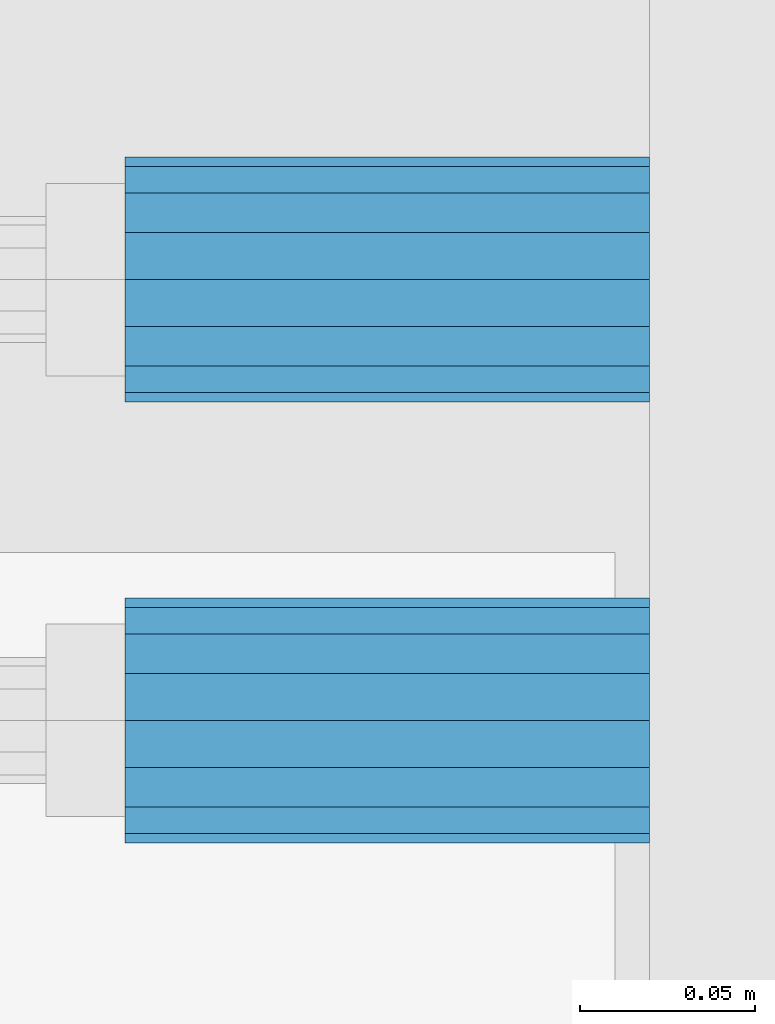
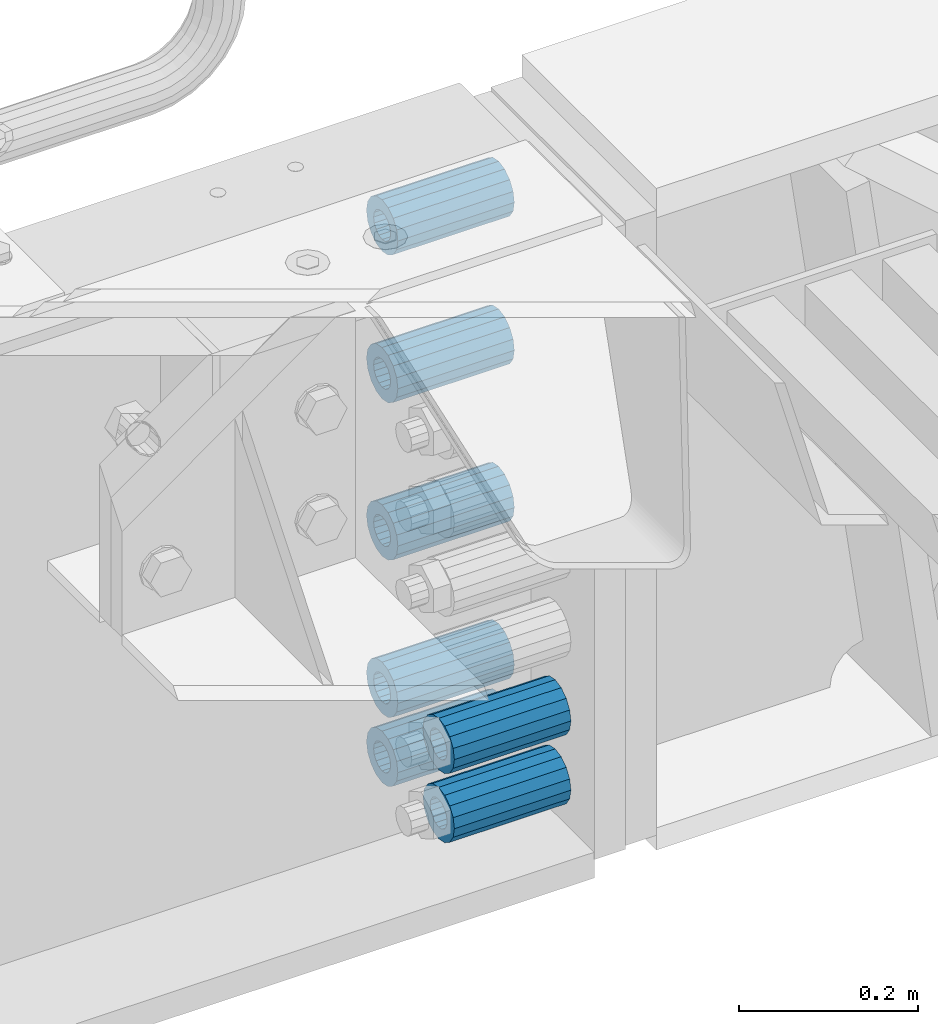
# One storey, part 172 of 242: 7 beams.
"""IFC2X3 building model written with IfcOpenShell, lengths in millimetres."""

from ifc_helpers import new_model, si_unit, frame, origin_with_axes, place, context, subcontext, project, spatial, faceted_brep, material, type_object, element, save


model = new_model("IFC2X3")

# Units and contexts
model_context = context("Model", 3, precision=1e-05, world=origin_with_axes())
body_context = subcontext(model_context, "Body", "Model", "MODEL_VIEW")
ifc_project = project(units=[si_unit("LENGTHUNIT", "METRE", prefix="MILLI"), si_unit("AREAUNIT", "SQUARE_METRE"), si_unit("VOLUMEUNIT", "CUBIC_METRE"), si_unit("MASSUNIT", "GRAM", prefix="KILO"), si_unit("TIMEUNIT", "SECOND"), si_unit("PLANEANGLEUNIT", "RADIAN"), si_unit("SOLIDANGLEUNIT", "STERADIAN"), si_unit("THERMODYNAMICTEMPERATUREUNIT", "DEGREE_CELSIUS"), si_unit("LUMINOUSINTENSITYUNIT", "LUMEN")], contexts=[model_context])

# Site, building, storey
site_placement = place(None, origin_with_axes())
site = spatial("IfcSite", under=ifc_project, at=site_placement, CompositionType="ELEMENT")
building_placement = place(site_placement, origin_with_axes())
building = spatial("IfcBuilding", under=site, at=building_placement, Name="Standard", CompositionType="ELEMENT")
storey_placement = place(building_placement, origin_with_axes())
storey = spatial("IfcBuildingStorey", under=building, at=storey_placement, Name="Undefined", CompositionType="ELEMENT", Elevation=0.0)

# Beams
ifc_material = material()
beam_type = type_object("IfcBeamType", PredefinedType="NOTDEFINED")
beam_1_placement = place(storey_placement, frame((-22210.0, -17937.0, -718.0), z_axis=(0.0, 0.0, 1.0), x_axis=(1.0, 0.0, 0.0)))
element("IfcBeam", 1, at=beam_1_placement, inside=storey, type_object=beam_type, material=ifc_material, context=body_context, shape_type="Brep", body=[
    faceted_brep([(1.33248249767348e-07, -19.0000000004493, -6.26823748461902e-09), (0.0, -17.5537111177146, 7.27098521493673), (150.0, -17.5537111177146, 7.27098521493673), (150.0, -19.0, 0.0), (0.0, -13.4350288425449, 13.4350288425444), (150.0, -13.4350288425449, 13.4350288425444), (0.0, -7.27098521493826, 17.5537111177144), (150.0, -7.27098521493826, 17.5537111177144), (-6.29370333626866e-09, -4.49290382675827e-10, 18.9999999937318), (150.0, 0.0, 19.0), (0.0, 7.27098521493826, 17.5537111177144), (150.0, 7.27098521493826, 17.5537111177144), (0.0, 13.4350288425449, 13.4350288425444), (150.0, 13.4350288425449, 13.4350288425444), (0.0, 17.5537111177146, 7.2709852149367), (150.0, 17.5537111177146, 7.2709852149367), (-1.31243723444641e-07, 18.9999999995507, -6.26823748461902e-09), (150.0, 19.0, 0.0), (0.0, 17.5537111177146, -7.2709852149367), (150.0, 17.5537111177146, -7.2709852149367), (0.0, 13.4350288425449, -13.4350288425444), (150.0, 13.4350288425449, -13.4350288425444), (0.0, 7.27098521493826, -17.5537111177144), (150.0, 7.27098521493826, -17.5537111177144), (8.2982296589762e-09, -4.49290382675827e-10, -19.0000000062719), (150.0, 0.0, -19.0), (0.0, -7.27098521493826, -17.5537111177144), (150.0, -7.27098521493826, -17.5537111177144), (0.0, -13.4350288425449, -13.4350288425444), (150.0, -13.4350288425449, -13.4350288425444), (0.0, -17.5537111177146, -7.2709852149367), (150.0, -17.5537111177146, -7.2709852149367), (-3.63797880709171e-12, -35.0, 0.0), (-3.63797880709171e-12, -32.335783637895, -13.3939201327812), (150.0, -32.3357836378964, -13.3939201327782), (150.0, -35.0, 0.0), (0.0, -24.7487373415292, -24.7487373415315), (150.0, -24.7487373415279, -24.7487373415292), (0.0, -13.3939201327782, -32.3357836378964), (150.0, -13.3939201327776, -32.335783637895), (0.0, 0.0, -35.0000000000036), (150.0, 0.0, -35.0), (0.0, 13.3939201327782, -32.3357836378964), (150.0, 13.3939201327776, -32.335783637895), (0.0, 24.7487373415292, -24.7487373415315), (150.0, 24.7487373415279, -24.7487373415292), (-3.63797880709171e-12, 32.335783637895, -13.3939201327812), (150.0, 32.3357836378964, -13.3939201327781), (-3.63797880709171e-12, 35.0, 0.0), (150.0, 35.0, 0.0), (-7.27595761418343e-12, 32.335783637895, 13.3939201327739), (150.0, 32.3357836378964, 13.3939201327781), (-7.27595761418343e-12, 24.7487373415292, 24.7487373415242), (150.0, 24.7487373415279, 24.7487373415292), (-7.27595761418343e-12, 13.3939201327781, 32.3357836378891), (150.0, 13.3939201327776, 32.335783637895), (-1.09139364212751e-11, 0.0, 34.9999999999964), (150.0, 0.0, 35.0), (-7.27595761418343e-12, -13.3939201327781, 32.3357836378891), (150.0, -13.3939201327776, 32.335783637895), (-7.27595761418343e-12, -24.7487373415292, 24.7487373415242), (150.0, -24.7487373415279, 24.7487373415292), (-7.27595761418343e-12, -32.335783637895, 13.3939201327739), (150.0, -32.3357836378964, 13.3939201327781)], [[[0, 1, 2, 3]], [[1, 4, 5, 2]], [[4, 6, 7, 5]], [[6, 8, 9, 7]], [[8, 10, 11, 9]], [[10, 12, 13, 11]], [[12, 14, 15, 13]], [[14, 16, 17, 15]], [[16, 18, 19, 17]], [[18, 20, 21, 19]], [[20, 22, 23, 21]], [[22, 24, 25, 23]], [[24, 26, 27, 25]], [[26, 28, 29, 27]], [[28, 30, 31, 29]], [[30, 0, 3, 31]], [[32, 33, 34, 35]], [[33, 36, 37, 34]], [[36, 38, 39, 37]], [[38, 40, 41, 39]], [[40, 42, 43, 41]], [[42, 44, 45, 43]], [[44, 46, 47, 45]], [[46, 48, 49, 47]], [[48, 50, 51, 49]], [[50, 52, 53, 51]], [[52, 54, 55, 53]], [[54, 56, 57, 55]], [[56, 58, 59, 57]], [[58, 60, 61, 59]], [[60, 62, 63, 61]], [[62, 32, 35, 63]], [[37, 39, 41, 43, 45, 47, 49, 51, 53, 55, 57, 59, 61, 63, 35, 34], [5, 7, 9, 11, 13, 15, 17, 19, 21, 23, 25, 27, 29, 31, 3, 2]], [[62, 60, 58, 56, 54, 52, 50, 48, 46, 44, 42, 40, 38, 36, 33, 32], [30, 28, 26, 24, 22, 20, 18, 16, 14, 12, 10, 8, 6, 4, 1, 0]]]),
])
beam_2_placement = place(storey_placement, frame((-22210.0, -17937.0, -504.0), z_axis=(0.0, 0.0, 1.0), x_axis=(1.0, 0.0, 0.0)))
element("IfcBeam", 2, at=beam_2_placement, inside=storey, type_object=beam_type, material=ifc_material, context=body_context, shape_type="Brep", body=[
    faceted_brep([(1.33248249767348e-07, -19.0000000004493, -6.26823748461902e-09), (0.0, -17.5537111177146, 7.27098521493673), (150.0, -17.5537111177146, 7.27098521493673), (150.0, -19.0, 0.0), (0.0, -13.4350288425449, 13.4350288425444), (150.0, -13.4350288425449, 13.4350288425444), (0.0, -7.27098521493826, 17.5537111177144), (150.0, -7.27098521493826, 17.5537111177144), (-6.29370333626866e-09, -4.49290382675827e-10, 18.9999999937318), (150.0, 0.0, 19.0), (0.0, 7.27098521493826, 17.5537111177144), (150.0, 7.27098521493826, 17.5537111177144), (0.0, 13.4350288425449, 13.4350288425444), (150.0, 13.4350288425449, 13.4350288425444), (0.0, 17.5537111177146, 7.2709852149367), (150.0, 17.5537111177146, 7.2709852149367), (-1.31243723444641e-07, 18.9999999995507, -6.26823748461902e-09), (150.0, 19.0, 0.0), (0.0, 17.5537111177146, -7.2709852149367), (150.0, 17.5537111177146, -7.2709852149367), (0.0, 13.4350288425449, -13.4350288425444), (150.0, 13.4350288425449, -13.4350288425444), (0.0, 7.27098521493826, -17.5537111177144), (150.0, 7.27098521493826, -17.5537111177144), (8.2982296589762e-09, -4.49290382675827e-10, -19.0000000062719), (150.0, 0.0, -19.0), (0.0, -7.27098521493826, -17.5537111177144), (150.0, -7.27098521493826, -17.5537111177144), (0.0, -13.4350288425449, -13.4350288425444), (150.0, -13.4350288425449, -13.4350288425444), (0.0, -17.5537111177146, -7.2709852149367), (150.0, -17.5537111177146, -7.2709852149367), (-3.63797880709171e-12, -35.0, 0.0), (-3.63797880709171e-12, -32.335783637895, -13.3939201327812), (150.0, -32.3357836378964, -13.3939201327782), (150.0, -35.0, 0.0), (0.0, -24.7487373415292, -24.7487373415315), (150.0, -24.7487373415279, -24.7487373415292), (0.0, -13.3939201327782, -32.3357836378964), (150.0, -13.3939201327776, -32.335783637895), (0.0, 0.0, -35.0000000000036), (150.0, 0.0, -35.0), (0.0, 13.3939201327782, -32.3357836378964), (150.0, 13.3939201327776, -32.335783637895), (0.0, 24.7487373415292, -24.7487373415315), (150.0, 24.7487373415279, -24.7487373415292), (-3.63797880709171e-12, 32.335783637895, -13.3939201327812), (150.0, 32.3357836378964, -13.3939201327781), (-3.63797880709171e-12, 35.0, 0.0), (150.0, 35.0, 0.0), (-7.27595761418343e-12, 32.335783637895, 13.3939201327739), (150.0, 32.3357836378964, 13.3939201327781), (-7.27595761418343e-12, 24.7487373415292, 24.7487373415242), (150.0, 24.7487373415279, 24.7487373415292), (-7.27595761418343e-12, 13.3939201327781, 32.3357836378891), (150.0, 13.3939201327776, 32.335783637895), (-1.09139364212751e-11, 0.0, 34.9999999999964), (150.0, 0.0, 35.0), (-7.27595761418343e-12, -13.3939201327781, 32.3357836378891), (150.0, -13.3939201327776, 32.335783637895), (-7.27595761418343e-12, -24.7487373415292, 24.7487373415242), (150.0, -24.7487373415279, 24.7487373415292), (-7.27595761418343e-12, -32.335783637895, 13.3939201327739), (150.0, -32.3357836378964, 13.3939201327781)], [[[0, 1, 2, 3]], [[1, 4, 5, 2]], [[4, 6, 7, 5]], [[6, 8, 9, 7]], [[8, 10, 11, 9]], [[10, 12, 13, 11]], [[12, 14, 15, 13]], [[14, 16, 17, 15]], [[16, 18, 19, 17]], [[18, 20, 21, 19]], [[20, 22, 23, 21]], [[22, 24, 25, 23]], [[24, 26, 27, 25]], [[26, 28, 29, 27]], [[28, 30, 31, 29]], [[30, 0, 3, 31]], [[32, 33, 34, 35]], [[33, 36, 37, 34]], [[36, 38, 39, 37]], [[38, 40, 41, 39]], [[40, 42, 43, 41]], [[42, 44, 45, 43]], [[44, 46, 47, 45]], [[46, 48, 49, 47]], [[48, 50, 51, 49]], [[50, 52, 53, 51]], [[52, 54, 55, 53]], [[54, 56, 57, 55]], [[56, 58, 59, 57]], [[58, 60, 61, 59]], [[60, 62, 63, 61]], [[62, 32, 35, 63]], [[37, 39, 41, 43, 45, 47, 49, 51, 53, 55, 57, 59, 61, 63, 35, 34], [5, 7, 9, 11, 13, 15, 17, 19, 21, 23, 25, 27, 29, 31, 3, 2]], [[62, 60, 58, 56, 54, 52, 50, 48, 46, 44, 42, 40, 38, 36, 33, 32], [30, 28, 26, 24, 22, 20, 18, 16, 14, 12, 10, 8, 6, 4, 1, 0]]]),
])
beam_3_placement = place(storey_placement, frame((-22210.0, -17937.0, -89.0000000000001), z_axis=(0.0, 0.0, 1.0), x_axis=(1.0, 0.0, 0.0)))
element("IfcBeam", 3, at=beam_3_placement, inside=storey, type_object=beam_type, material=ifc_material, context=body_context, shape_type="Brep", body=[
    faceted_brep([(1.33248249767348e-07, -19.0000000004493, -6.26823748461902e-09), (0.0, -17.5537111177146, 7.27098521493673), (150.0, -17.5537111177146, 7.27098521493673), (150.0, -19.0, 0.0), (0.0, -13.4350288425449, 13.4350288425444), (150.0, -13.4350288425449, 13.4350288425444), (0.0, -7.27098521493826, 17.5537111177144), (150.0, -7.27098521493826, 17.5537111177144), (-6.29370333626866e-09, -4.49290382675827e-10, 18.9999999937318), (150.0, 0.0, 19.0), (0.0, 7.27098521493826, 17.5537111177144), (150.0, 7.27098521493826, 17.5537111177144), (0.0, 13.4350288425449, 13.4350288425444), (150.0, 13.4350288425449, 13.4350288425444), (0.0, 17.5537111177146, 7.2709852149367), (150.0, 17.5537111177146, 7.2709852149367), (-1.31243723444641e-07, 18.9999999995507, -6.26823748461902e-09), (150.0, 19.0, 0.0), (0.0, 17.5537111177146, -7.2709852149367), (150.0, 17.5537111177146, -7.2709852149367), (0.0, 13.4350288425449, -13.4350288425444), (150.0, 13.4350288425449, -13.4350288425444), (0.0, 7.27098521493826, -17.5537111177144), (150.0, 7.27098521493826, -17.5537111177144), (8.2982296589762e-09, -4.49290382675827e-10, -19.0000000062719), (150.0, 0.0, -19.0), (0.0, -7.27098521493826, -17.5537111177144), (150.0, -7.27098521493826, -17.5537111177144), (0.0, -13.4350288425449, -13.4350288425444), (150.0, -13.4350288425449, -13.4350288425444), (0.0, -17.5537111177146, -7.2709852149367), (150.0, -17.5537111177146, -7.2709852149367), (-3.63797880709171e-12, -35.0, 0.0), (-3.63797880709171e-12, -32.335783637895, -13.3939201327812), (150.0, -32.3357836378964, -13.3939201327782), (150.0, -35.0, 0.0), (0.0, -24.7487373415292, -24.7487373415315), (150.0, -24.7487373415279, -24.7487373415292), (0.0, -13.3939201327782, -32.3357836378964), (150.0, -13.3939201327776, -32.335783637895), (0.0, 0.0, -35.0000000000036), (150.0, 0.0, -35.0), (0.0, 13.3939201327782, -32.3357836378964), (150.0, 13.3939201327776, -32.335783637895), (0.0, 24.7487373415292, -24.7487373415315), (150.0, 24.7487373415279, -24.7487373415292), (-3.63797880709171e-12, 32.335783637895, -13.3939201327812), (150.0, 32.3357836378964, -13.3939201327781), (-3.63797880709171e-12, 35.0, 0.0), (150.0, 35.0, 0.0), (-7.27595761418343e-12, 32.335783637895, 13.3939201327739), (150.0, 32.3357836378964, 13.3939201327781), (-7.27595761418343e-12, 24.7487373415292, 24.7487373415242), (150.0, 24.7487373415279, 24.7487373415292), (-7.27595761418343e-12, 13.3939201327781, 32.3357836378891), (150.0, 13.3939201327776, 32.335783637895), (-1.09139364212751e-11, 0.0, 34.9999999999964), (150.0, 0.0, 35.0), (-7.27595761418343e-12, -13.3939201327781, 32.3357836378891), (150.0, -13.3939201327776, 32.335783637895), (-7.27595761418343e-12, -24.7487373415292, 24.7487373415242), (150.0, -24.7487373415279, 24.7487373415292), (-7.27595761418343e-12, -32.335783637895, 13.3939201327739), (150.0, -32.3357836378964, 13.3939201327781)], [[[0, 1, 2, 3]], [[1, 4, 5, 2]], [[4, 6, 7, 5]], [[6, 8, 9, 7]], [[8, 10, 11, 9]], [[10, 12, 13, 11]], [[12, 14, 15, 13]], [[14, 16, 17, 15]], [[16, 18, 19, 17]], [[18, 20, 21, 19]], [[20, 22, 23, 21]], [[22, 24, 25, 23]], [[24, 26, 27, 25]], [[26, 28, 29, 27]], [[28, 30, 31, 29]], [[30, 0, 3, 31]], [[32, 33, 34, 35]], [[33, 36, 37, 34]], [[36, 38, 39, 37]], [[38, 40, 41, 39]], [[40, 42, 43, 41]], [[42, 44, 45, 43]], [[44, 46, 47, 45]], [[46, 48, 49, 47]], [[48, 50, 51, 49]], [[50, 52, 53, 51]], [[52, 54, 55, 53]], [[54, 56, 57, 55]], [[56, 58, 59, 57]], [[58, 60, 61, 59]], [[60, 62, 63, 61]], [[62, 32, 35, 63]], [[37, 39, 41, 43, 45, 47, 49, 51, 53, 55, 57, 59, 61, 63, 35, 34], [5, 7, 9, 11, 13, 15, 17, 19, 21, 23, 25, 27, 29, 31, 3, 2]], [[62, 60, 58, 56, 54, 52, 50, 48, 46, 44, 42, 40, 38, 36, 33, 32], [30, 28, 26, 24, 22, 20, 18, 16, 14, 12, 10, 8, 6, 4, 1, 0]]]),
])
beam_4_placement = place(storey_placement, frame((-22210.0, -17937.0, -290.0), z_axis=(0.0, 0.0, 1.0), x_axis=(1.0, 0.0, 0.0)))
element("IfcBeam", 4, at=beam_4_placement, inside=storey, type_object=beam_type, material=ifc_material, context=body_context, shape_type="Brep", body=[
    faceted_brep([(1.33248249767348e-07, -19.0000000004493, -6.26823748461902e-09), (0.0, -17.5537111177146, 7.27098521493673), (150.0, -17.5537111177146, 7.27098521493673), (150.0, -19.0, 0.0), (0.0, -13.4350288425449, 13.4350288425444), (150.0, -13.4350288425449, 13.4350288425444), (0.0, -7.27098521493826, 17.5537111177144), (150.0, -7.27098521493826, 17.5537111177144), (-6.29370333626866e-09, -4.49290382675827e-10, 18.9999999937318), (150.0, 0.0, 19.0), (0.0, 7.27098521493826, 17.5537111177144), (150.0, 7.27098521493826, 17.5537111177144), (0.0, 13.4350288425449, 13.4350288425444), (150.0, 13.4350288425449, 13.4350288425444), (0.0, 17.5537111177146, 7.2709852149367), (150.0, 17.5537111177146, 7.2709852149367), (-1.31243723444641e-07, 18.9999999995507, -6.26823748461902e-09), (150.0, 19.0, 0.0), (0.0, 17.5537111177146, -7.2709852149367), (150.0, 17.5537111177146, -7.2709852149367), (0.0, 13.4350288425449, -13.4350288425444), (150.0, 13.4350288425449, -13.4350288425444), (0.0, 7.27098521493826, -17.5537111177144), (150.0, 7.27098521493826, -17.5537111177144), (8.2982296589762e-09, -4.49290382675827e-10, -19.0000000062719), (150.0, 0.0, -19.0), (0.0, -7.27098521493826, -17.5537111177144), (150.0, -7.27098521493826, -17.5537111177144), (0.0, -13.4350288425449, -13.4350288425444), (150.0, -13.4350288425449, -13.4350288425444), (0.0, -17.5537111177146, -7.2709852149367), (150.0, -17.5537111177146, -7.2709852149367), (-3.63797880709171e-12, -35.0, 0.0), (-3.63797880709171e-12, -32.335783637895, -13.3939201327812), (150.0, -32.3357836378964, -13.3939201327782), (150.0, -35.0, 0.0), (0.0, -24.7487373415292, -24.7487373415315), (150.0, -24.7487373415279, -24.7487373415292), (0.0, -13.3939201327782, -32.3357836378964), (150.0, -13.3939201327776, -32.335783637895), (0.0, 0.0, -35.0000000000036), (150.0, 0.0, -35.0), (0.0, 13.3939201327782, -32.3357836378964), (150.0, 13.3939201327776, -32.335783637895), (0.0, 24.7487373415292, -24.7487373415315), (150.0, 24.7487373415279, -24.7487373415292), (-3.63797880709171e-12, 32.335783637895, -13.3939201327812), (150.0, 32.3357836378964, -13.3939201327781), (-3.63797880709171e-12, 35.0, 0.0), (150.0, 35.0, 0.0), (-7.27595761418343e-12, 32.335783637895, 13.3939201327739), (150.0, 32.3357836378964, 13.3939201327781), (-7.27595761418343e-12, 24.7487373415292, 24.7487373415242), (150.0, 24.7487373415279, 24.7487373415292), (-7.27595761418343e-12, 13.3939201327781, 32.3357836378891), (150.0, 13.3939201327776, 32.335783637895), (-1.09139364212751e-11, 0.0, 34.9999999999964), (150.0, 0.0, 35.0), (-7.27595761418343e-12, -13.3939201327781, 32.3357836378891), (150.0, -13.3939201327776, 32.335783637895), (-7.27595761418343e-12, -24.7487373415292, 24.7487373415242), (150.0, -24.7487373415279, 24.7487373415292), (-7.27595761418343e-12, -32.335783637895, 13.3939201327739), (150.0, -32.3357836378964, 13.3939201327781)], [[[0, 1, 2, 3]], [[1, 4, 5, 2]], [[4, 6, 7, 5]], [[6, 8, 9, 7]], [[8, 10, 11, 9]], [[10, 12, 13, 11]], [[12, 14, 15, 13]], [[14, 16, 17, 15]], [[16, 18, 19, 17]], [[18, 20, 21, 19]], [[20, 22, 23, 21]], [[22, 24, 25, 23]], [[24, 26, 27, 25]], [[26, 28, 29, 27]], [[28, 30, 31, 29]], [[30, 0, 3, 31]], [[32, 33, 34, 35]], [[33, 36, 37, 34]], [[36, 38, 39, 37]], [[38, 40, 41, 39]], [[40, 42, 43, 41]], [[42, 44, 45, 43]], [[44, 46, 47, 45]], [[46, 48, 49, 47]], [[48, 50, 51, 49]], [[50, 52, 53, 51]], [[52, 54, 55, 53]], [[54, 56, 57, 55]], [[56, 58, 59, 57]], [[58, 60, 61, 59]], [[60, 62, 63, 61]], [[62, 32, 35, 63]], [[37, 39, 41, 43, 45, 47, 49, 51, 53, 55, 57, 59, 61, 63, 35, 34], [5, 7, 9, 11, 13, 15, 17, 19, 21, 23, 25, 27, 29, 31, 3, 2]], [[62, 60, 58, 56, 54, 52, 50, 48, 46, 44, 42, 40, 38, 36, 33, 32], [30, 28, 26, 24, 22, 20, 18, 16, 14, 12, 10, 8, 6, 4, 1, 0]]]),
])
beam_5_placement = place(storey_placement, frame((-22210.0, -18063.0, -718.0), z_axis=(0.0, 0.0, 1.0), x_axis=(1.0, 0.0, 0.0)))
element("IfcBeam", 5, at=beam_5_placement, inside=storey, type_object=beam_type, material=ifc_material, context=body_context, shape_type="Brep", body=[
    faceted_brep([(1.33248249767348e-07, -19.0000000004493, -6.26823748461902e-09), (0.0, -17.5537111177146, 7.27098521493673), (150.0, -17.5537111177146, 7.27098521493673), (150.0, -19.0, 0.0), (0.0, -13.4350288425449, 13.4350288425444), (150.0, -13.4350288425449, 13.4350288425444), (0.0, -7.27098521493826, 17.5537111177144), (150.0, -7.27098521493826, 17.5537111177144), (-6.29370333626866e-09, -4.49290382675827e-10, 18.9999999937318), (150.0, 0.0, 19.0), (0.0, 7.27098521493826, 17.5537111177144), (150.0, 7.27098521493826, 17.5537111177144), (0.0, 13.4350288425449, 13.4350288425444), (150.0, 13.4350288425449, 13.4350288425444), (0.0, 17.5537111177146, 7.2709852149367), (150.0, 17.5537111177146, 7.2709852149367), (-1.31243723444641e-07, 18.9999999995507, -6.26823748461902e-09), (150.0, 19.0, 0.0), (0.0, 17.5537111177146, -7.2709852149367), (150.0, 17.5537111177146, -7.2709852149367), (0.0, 13.4350288425449, -13.4350288425444), (150.0, 13.4350288425449, -13.4350288425444), (0.0, 7.27098521493826, -17.5537111177144), (150.0, 7.27098521493826, -17.5537111177144), (8.2982296589762e-09, -4.49290382675827e-10, -19.0000000062719), (150.0, 0.0, -19.0), (0.0, -7.27098521493826, -17.5537111177144), (150.0, -7.27098521493826, -17.5537111177144), (0.0, -13.4350288425449, -13.4350288425444), (150.0, -13.4350288425449, -13.4350288425444), (0.0, -17.5537111177146, -7.2709852149367), (150.0, -17.5537111177146, -7.2709852149367), (-3.63797880709171e-12, -35.0, 0.0), (-3.63797880709171e-12, -32.335783637895, -13.3939201327812), (150.0, -32.3357836378964, -13.3939201327782), (150.0, -35.0, 0.0), (0.0, -24.7487373415292, -24.7487373415315), (150.0, -24.7487373415279, -24.7487373415292), (0.0, -13.3939201327782, -32.3357836378964), (150.0, -13.3939201327776, -32.335783637895), (0.0, 0.0, -35.0000000000036), (150.0, 0.0, -35.0), (0.0, 13.3939201327782, -32.3357836378964), (150.0, 13.3939201327776, -32.335783637895), (0.0, 24.7487373415292, -24.7487373415315), (150.0, 24.7487373415279, -24.7487373415292), (-3.63797880709171e-12, 32.335783637895, -13.3939201327812), (150.0, 32.3357836378964, -13.3939201327781), (-3.63797880709171e-12, 35.0, 0.0), (150.0, 35.0, 0.0), (-7.27595761418343e-12, 32.335783637895, 13.3939201327739), (150.0, 32.3357836378964, 13.3939201327781), (-7.27595761418343e-12, 24.7487373415292, 24.7487373415242), (150.0, 24.7487373415279, 24.7487373415292), (-7.27595761418343e-12, 13.3939201327781, 32.3357836378891), (150.0, 13.3939201327776, 32.335783637895), (-1.09139364212751e-11, 0.0, 34.9999999999964), (150.0, 0.0, 35.0), (-7.27595761418343e-12, -13.3939201327781, 32.3357836378891), (150.0, -13.3939201327776, 32.335783637895), (-7.27595761418343e-12, -24.7487373415292, 24.7487373415242), (150.0, -24.7487373415279, 24.7487373415292), (-7.27595761418343e-12, -32.335783637895, 13.3939201327739), (150.0, -32.3357836378964, 13.3939201327781)], [[[0, 1, 2, 3]], [[1, 4, 5, 2]], [[4, 6, 7, 5]], [[6, 8, 9, 7]], [[8, 10, 11, 9]], [[10, 12, 13, 11]], [[12, 14, 15, 13]], [[14, 16, 17, 15]], [[16, 18, 19, 17]], [[18, 20, 21, 19]], [[20, 22, 23, 21]], [[22, 24, 25, 23]], [[24, 26, 27, 25]], [[26, 28, 29, 27]], [[28, 30, 31, 29]], [[30, 0, 3, 31]], [[32, 33, 34, 35]], [[33, 36, 37, 34]], [[36, 38, 39, 37]], [[38, 40, 41, 39]], [[40, 42, 43, 41]], [[42, 44, 45, 43]], [[44, 46, 47, 45]], [[46, 48, 49, 47]], [[48, 50, 51, 49]], [[50, 52, 53, 51]], [[52, 54, 55, 53]], [[54, 56, 57, 55]], [[56, 58, 59, 57]], [[58, 60, 61, 59]], [[60, 62, 63, 61]], [[62, 32, 35, 63]], [[37, 39, 41, 43, 45, 47, 49, 51, 53, 55, 57, 59, 61, 63, 35, 34], [5, 7, 9, 11, 13, 15, 17, 19, 21, 23, 25, 27, 29, 31, 3, 2]], [[62, 60, 58, 56, 54, 52, 50, 48, 46, 44, 42, 40, 38, 36, 33, 32], [30, 28, 26, 24, 22, 20, 18, 16, 14, 12, 10, 8, 6, 4, 1, 0]]]),
])
beam_6_placement = place(storey_placement, frame((-22210.0, -17937.0, -812.0), z_axis=(0.0, 0.0, 1.0), x_axis=(1.0, 0.0, 0.0)))
element("IfcBeam", 6, at=beam_6_placement, inside=storey, type_object=beam_type, material=ifc_material, context=body_context, shape_type="Brep", body=[
    faceted_brep([(1.33248249767348e-07, -19.0000000004493, -6.26823748461902e-09), (0.0, -17.5537111177146, 7.27098521493673), (150.0, -17.5537111177146, 7.27098521493673), (150.0, -19.0, 0.0), (0.0, -13.4350288425449, 13.4350288425444), (150.0, -13.4350288425449, 13.4350288425444), (0.0, -7.27098521493826, 17.5537111177144), (150.0, -7.27098521493826, 17.5537111177144), (-6.29370333626866e-09, -4.49290382675827e-10, 18.9999999937318), (150.0, 0.0, 19.0), (0.0, 7.27098521493826, 17.5537111177144), (150.0, 7.27098521493826, 17.5537111177144), (0.0, 13.4350288425449, 13.4350288425444), (150.0, 13.4350288425449, 13.4350288425444), (0.0, 17.5537111177146, 7.2709852149367), (150.0, 17.5537111177146, 7.2709852149367), (-1.31243723444641e-07, 18.9999999995507, -6.26823748461902e-09), (150.0, 19.0, 0.0), (0.0, 17.5537111177146, -7.2709852149367), (150.0, 17.5537111177146, -7.2709852149367), (0.0, 13.4350288425449, -13.4350288425444), (150.0, 13.4350288425449, -13.4350288425444), (0.0, 7.27098521493826, -17.5537111177144), (150.0, 7.27098521493826, -17.5537111177144), (8.2982296589762e-09, -4.49290382675827e-10, -19.0000000062719), (150.0, 0.0, -19.0), (0.0, -7.27098521493826, -17.5537111177144), (150.0, -7.27098521493826, -17.5537111177144), (0.0, -13.4350288425449, -13.4350288425444), (150.0, -13.4350288425449, -13.4350288425444), (0.0, -17.5537111177146, -7.2709852149367), (150.0, -17.5537111177146, -7.2709852149367), (-3.63797880709171e-12, -35.0, 0.0), (-3.63797880709171e-12, -32.335783637895, -13.3939201327812), (150.0, -32.3357836378964, -13.3939201327782), (150.0, -35.0, 0.0), (0.0, -24.7487373415292, -24.7487373415315), (150.0, -24.7487373415279, -24.7487373415292), (0.0, -13.3939201327782, -32.3357836378964), (150.0, -13.3939201327776, -32.335783637895), (0.0, 0.0, -35.0000000000036), (150.0, 0.0, -35.0), (0.0, 13.3939201327782, -32.3357836378964), (150.0, 13.3939201327776, -32.335783637895), (0.0, 24.7487373415292, -24.7487373415315), (150.0, 24.7487373415279, -24.7487373415292), (-3.63797880709171e-12, 32.335783637895, -13.3939201327812), (150.0, 32.3357836378964, -13.3939201327781), (-3.63797880709171e-12, 35.0, 0.0), (150.0, 35.0, 0.0), (-7.27595761418343e-12, 32.335783637895, 13.3939201327739), (150.0, 32.3357836378964, 13.3939201327781), (-7.27595761418343e-12, 24.7487373415292, 24.7487373415242), (150.0, 24.7487373415279, 24.7487373415292), (-7.27595761418343e-12, 13.3939201327781, 32.3357836378891), (150.0, 13.3939201327776, 32.335783637895), (-1.09139364212751e-11, 0.0, 34.9999999999964), (150.0, 0.0, 35.0), (-7.27595761418343e-12, -13.3939201327781, 32.3357836378891), (150.0, -13.3939201327776, 32.335783637895), (-7.27595761418343e-12, -24.7487373415292, 24.7487373415242), (150.0, -24.7487373415279, 24.7487373415292), (-7.27595761418343e-12, -32.335783637895, 13.3939201327739), (150.0, -32.3357836378964, 13.3939201327781)], [[[0, 1, 2, 3]], [[1, 4, 5, 2]], [[4, 6, 7, 5]], [[6, 8, 9, 7]], [[8, 10, 11, 9]], [[10, 12, 13, 11]], [[12, 14, 15, 13]], [[14, 16, 17, 15]], [[16, 18, 19, 17]], [[18, 20, 21, 19]], [[20, 22, 23, 21]], [[22, 24, 25, 23]], [[24, 26, 27, 25]], [[26, 28, 29, 27]], [[28, 30, 31, 29]], [[30, 0, 3, 31]], [[32, 33, 34, 35]], [[33, 36, 37, 34]], [[36, 38, 39, 37]], [[38, 40, 41, 39]], [[40, 42, 43, 41]], [[42, 44, 45, 43]], [[44, 46, 47, 45]], [[46, 48, 49, 47]], [[48, 50, 51, 49]], [[50, 52, 53, 51]], [[52, 54, 55, 53]], [[54, 56, 57, 55]], [[56, 58, 59, 57]], [[58, 60, 61, 59]], [[60, 62, 63, 61]], [[62, 32, 35, 63]], [[37, 39, 41, 43, 45, 47, 49, 51, 53, 55, 57, 59, 61, 63, 35, 34], [5, 7, 9, 11, 13, 15, 17, 19, 21, 23, 25, 27, 29, 31, 3, 2]], [[62, 60, 58, 56, 54, 52, 50, 48, 46, 44, 42, 40, 38, 36, 33, 32], [30, 28, 26, 24, 22, 20, 18, 16, 14, 12, 10, 8, 6, 4, 1, 0]]]),
])
beam_7_placement = place(storey_placement, frame((-22210.0, -18063.0, -812.0), z_axis=(0.0, 0.0, 1.0), x_axis=(1.0, 0.0, 0.0)))
element("IfcBeam", 7, at=beam_7_placement, inside=storey, type_object=beam_type, material=ifc_material, context=body_context, shape_type="Brep", body=[
    faceted_brep([(1.33248249767348e-07, -19.0000000004493, -6.26823748461902e-09), (0.0, -17.5537111177146, 7.27098521493673), (150.0, -17.5537111177146, 7.27098521493673), (150.0, -19.0, 0.0), (0.0, -13.4350288425449, 13.4350288425444), (150.0, -13.4350288425449, 13.4350288425444), (0.0, -7.27098521493826, 17.5537111177144), (150.0, -7.27098521493826, 17.5537111177144), (-6.29370333626866e-09, -4.49290382675827e-10, 18.9999999937318), (150.0, 0.0, 19.0), (0.0, 7.27098521493826, 17.5537111177144), (150.0, 7.27098521493826, 17.5537111177144), (0.0, 13.4350288425449, 13.4350288425444), (150.0, 13.4350288425449, 13.4350288425444), (0.0, 17.5537111177146, 7.2709852149367), (150.0, 17.5537111177146, 7.2709852149367), (-1.31243723444641e-07, 18.9999999995507, -6.26823748461902e-09), (150.0, 19.0, 0.0), (0.0, 17.5537111177146, -7.2709852149367), (150.0, 17.5537111177146, -7.2709852149367), (0.0, 13.4350288425449, -13.4350288425444), (150.0, 13.4350288425449, -13.4350288425444), (0.0, 7.27098521493826, -17.5537111177144), (150.0, 7.27098521493826, -17.5537111177144), (8.2982296589762e-09, -4.49290382675827e-10, -19.0000000062719), (150.0, 0.0, -19.0), (0.0, -7.27098521493826, -17.5537111177144), (150.0, -7.27098521493826, -17.5537111177144), (0.0, -13.4350288425449, -13.4350288425444), (150.0, -13.4350288425449, -13.4350288425444), (0.0, -17.5537111177146, -7.2709852149367), (150.0, -17.5537111177146, -7.2709852149367), (-3.63797880709171e-12, -35.0, 0.0), (-3.63797880709171e-12, -32.335783637895, -13.3939201327812), (150.0, -32.3357836378964, -13.3939201327782), (150.0, -35.0, 0.0), (0.0, -24.7487373415292, -24.7487373415315), (150.0, -24.7487373415279, -24.7487373415292), (0.0, -13.3939201327782, -32.3357836378964), (150.0, -13.3939201327776, -32.335783637895), (0.0, 0.0, -35.0000000000036), (150.0, 0.0, -35.0), (0.0, 13.3939201327782, -32.3357836378964), (150.0, 13.3939201327776, -32.335783637895), (0.0, 24.7487373415292, -24.7487373415315), (150.0, 24.7487373415279, -24.7487373415292), (-3.63797880709171e-12, 32.335783637895, -13.3939201327812), (150.0, 32.3357836378964, -13.3939201327781), (-3.63797880709171e-12, 35.0, 0.0), (150.0, 35.0, 0.0), (-7.27595761418343e-12, 32.335783637895, 13.3939201327739), (150.0, 32.3357836378964, 13.3939201327781), (-7.27595761418343e-12, 24.7487373415292, 24.7487373415242), (150.0, 24.7487373415279, 24.7487373415292), (-7.27595761418343e-12, 13.3939201327781, 32.3357836378891), (150.0, 13.3939201327776, 32.335783637895), (-1.09139364212751e-11, 0.0, 34.9999999999964), (150.0, 0.0, 35.0), (-7.27595761418343e-12, -13.3939201327781, 32.3357836378891), (150.0, -13.3939201327776, 32.335783637895), (-7.27595761418343e-12, -24.7487373415292, 24.7487373415242), (150.0, -24.7487373415279, 24.7487373415292), (-7.27595761418343e-12, -32.335783637895, 13.3939201327739), (150.0, -32.3357836378964, 13.3939201327781)], [[[0, 1, 2, 3]], [[1, 4, 5, 2]], [[4, 6, 7, 5]], [[6, 8, 9, 7]], [[8, 10, 11, 9]], [[10, 12, 13, 11]], [[12, 14, 15, 13]], [[14, 16, 17, 15]], [[16, 18, 19, 17]], [[18, 20, 21, 19]], [[20, 22, 23, 21]], [[22, 24, 25, 23]], [[24, 26, 27, 25]], [[26, 28, 29, 27]], [[28, 30, 31, 29]], [[30, 0, 3, 31]], [[32, 33, 34, 35]], [[33, 36, 37, 34]], [[36, 38, 39, 37]], [[38, 40, 41, 39]], [[40, 42, 43, 41]], [[42, 44, 45, 43]], [[44, 46, 47, 45]], [[46, 48, 49, 47]], [[48, 50, 51, 49]], [[50, 52, 53, 51]], [[52, 54, 55, 53]], [[54, 56, 57, 55]], [[56, 58, 59, 57]], [[58, 60, 61, 59]], [[60, 62, 63, 61]], [[62, 32, 35, 63]], [[37, 39, 41, 43, 45, 47, 49, 51, 53, 55, 57, 59, 61, 63, 35, 34], [5, 7, 9, 11, 13, 15, 17, 19, 21, 23, 25, 27, 29, 31, 3, 2]], [[62, 60, 58, 56, 54, 52, 50, 48, 46, 44, 42, 40, 38, 36, 33, 32], [30, 28, 26, 24, 22, 20, 18, 16, 14, 12, 10, 8, 6, 4, 1, 0]]]),
])

save(model, "model.ifc")
